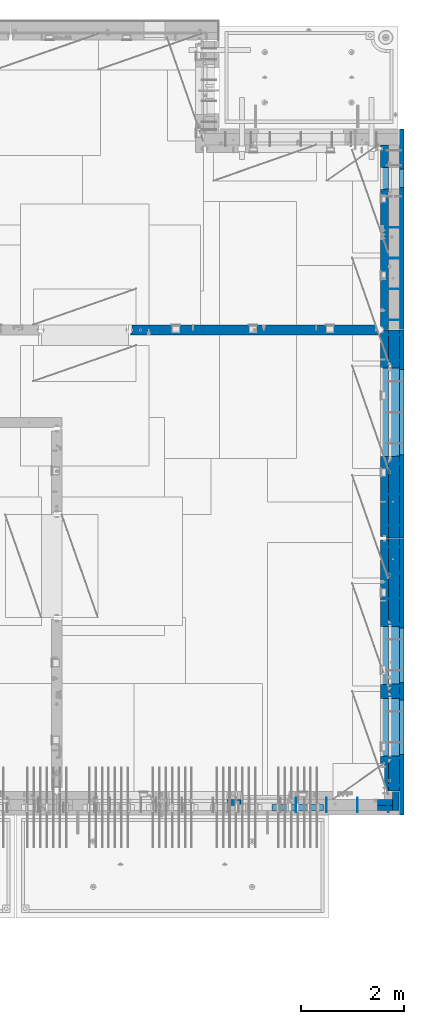
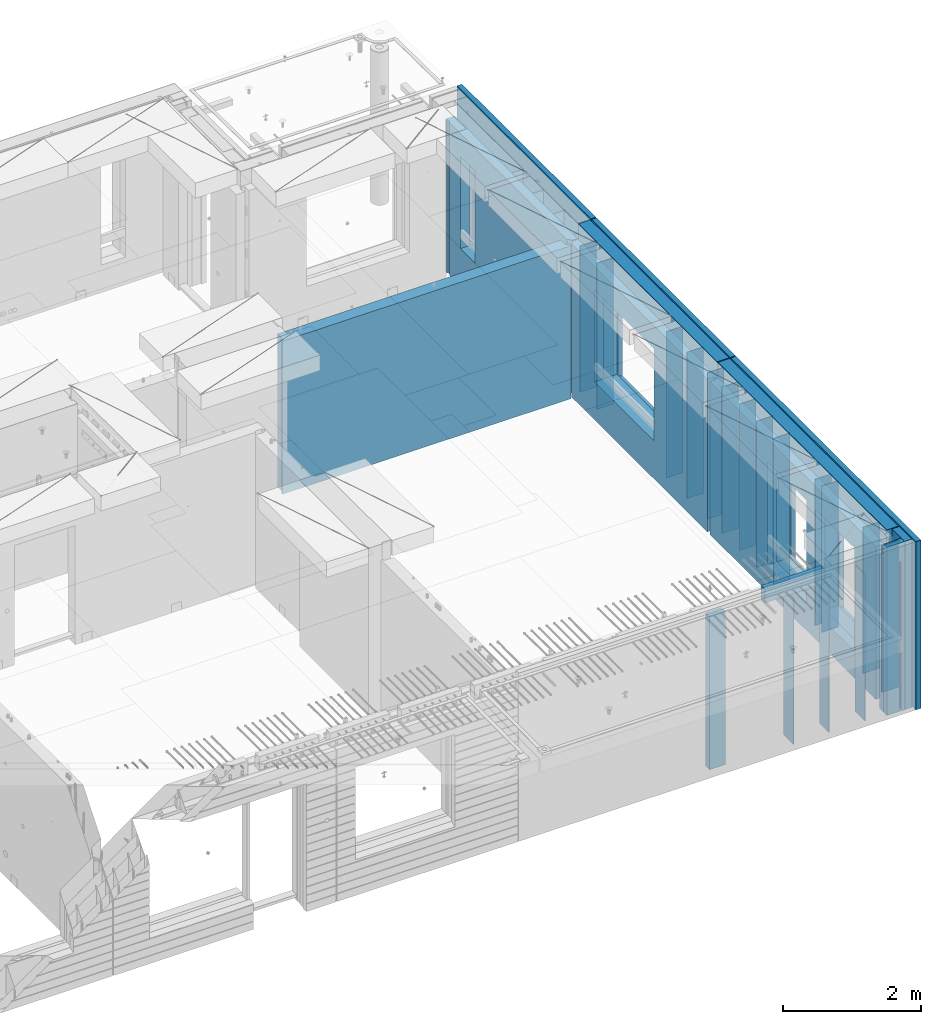
# One storey, part 242 of 350: 36 walls, 10 elements without a shape of their own.
"""IFC2X3 building model written with IfcOpenShell, lengths in millimetres."""

from ifc_helpers import new_model, si_unit, frame, origin_with_axes, place, context, subcontext, project, spatial, faceted_brep, material, type_object, element, aggregate, save


model = new_model("IFC2X3")

# Units and contexts
model_context = context("Model", 3, precision=1e-05, world=origin_with_axes())
body_context = subcontext(model_context, "Body", "Model", "MODEL_VIEW")
ifc_project = project(units=[si_unit("LENGTHUNIT", "METRE", prefix="MILLI"), si_unit("AREAUNIT", "SQUARE_METRE"), si_unit("VOLUMEUNIT", "CUBIC_METRE"), si_unit("MASSUNIT", "GRAM", prefix="KILO"), si_unit("TIMEUNIT", "SECOND"), si_unit("PLANEANGLEUNIT", "RADIAN"), si_unit("SOLIDANGLEUNIT", "STERADIAN"), si_unit("THERMODYNAMICTEMPERATUREUNIT", "DEGREE_CELSIUS"), si_unit("LUMINOUSINTENSITYUNIT", "LUMEN")], contexts=[model_context])

# Site, building, storey
site_placement = place(None, origin_with_axes())
site = spatial("IfcSite", under=ifc_project, at=site_placement, CompositionType="ELEMENT")
building_placement = place(site_placement, origin_with_axes())
building = spatial("IfcBuilding", under=site, at=building_placement, CompositionType="ELEMENT")
storey_placement = place(building_placement, origin_with_axes())
storey = spatial("IfcBuildingStorey", under=building, at=storey_placement, Name="2", CompositionType="ELEMENT", Elevation=0.0)

# Assembly, wall
assembly_1_placement = place(storey_placement, origin_with_axes())
assembly_1 = element("IfcElementAssembly", 1, at=assembly_1_placement, inside=storey, AssemblyPlace="NOTDEFINED", PredefinedType="REINFORCEMENT_UNIT")
ifc_material_1 = material(Name="Undefined")
wall_type_1 = type_object("IfcWallType", PredefinedType="NOTDEFINED")
wall_1_placement = place(assembly_1_placement, frame((35060.0, 7780.0, 86115.0), z_axis=(0.0, 0.0, 1.0), x_axis=(0.0, -1.0, 0.0)))
wall_1 = element("IfcWall", 2, at=wall_1_placement, type_object=wall_type_1, material=ifc_material_1, Name="(PD)", context=body_context, shape_type="Brep", body=[
    faceted_brep([(0.0, 5.0, -1300.0), (0.0, 5.0, 1300.0), (180.0, 5.0, 1300.0), (180.0, 5.0, -1300.0), (0.0, -5.0, 1300.0), (180.0, -5.0, 1300.0), (0.0, -5.0, -1300.0), (180.0, -5.0, -1300.0)], [[[0, 1, 2, 3]], [[1, 4, 5, 2]], [[4, 6, 7, 5]], [[6, 0, 3, 7]], [[5, 7, 3, 2]], [[6, 4, 1, 0]]]),
])

assembly_2_placement = place(storey_placement, origin_with_axes())
assembly_2 = element("IfcElementAssembly", 3, at=assembly_2_placement, inside=storey, Name="Steel Assembly", AssemblyPlace="NOTDEFINED", PredefinedType="NOTDEFINED")
wall_2_placement = place(assembly_2_placement, frame((34460.0, 7880.0, 86115.0), z_axis=(0.0, 0.0, 1.0), x_axis=(0.0, -1.0, 0.0)))
wall_2 = element("IfcWall", 4, at=wall_2_placement, type_object=wall_type_1, material=ifc_material_1, Name="(PD)", context=body_context, shape_type="Brep", body=[
    faceted_brep([(0.0, 5.0, -1300.0), (0.0, 5.0, 1300.0), (280.0, 5.0, 1300.0), (280.0, 5.0, -1300.0), (0.0, -5.0, 1300.0), (280.0, -5.0, 1300.0), (0.0, -5.0, -1300.0), (280.0, -5.0, -1300.0)], [[[0, 1, 2, 3]], [[1, 4, 5, 2]], [[4, 6, 7, 5]], [[6, 0, 3, 7]], [[5, 7, 3, 2]], [[6, 4, 1, 0]]]),
])
aggregate(assembly_2, [wall_2])

assembly_3_placement = place(storey_placement, origin_with_axes())
assembly_3 = element("IfcElementAssembly", 5, at=assembly_3_placement, inside=storey, Name="Steel Assembly", AssemblyPlace="NOTDEFINED", PredefinedType="NOTDEFINED")
wall_3_placement = place(assembly_3_placement, frame((33860.0, 7880.0, 86115.0), z_axis=(0.0, 0.0, 1.0), x_axis=(0.0, -1.0, 0.0)))
wall_3 = element("IfcWall", 6, at=wall_3_placement, type_object=wall_type_1, material=ifc_material_1, Name="(PD)", context=body_context, shape_type="Brep", body=[
    faceted_brep([(0.0, 5.0, -1300.0), (0.0, 5.0, 1300.0), (280.0, 5.0, 1300.0), (280.0, 5.0, -1300.0), (0.0, -5.0, 1300.0), (280.0, -5.0, 1300.0), (0.0, -5.0, -1300.0), (280.0, -5.0, -1300.0)], [[[0, 1, 2, 3]], [[1, 4, 5, 2]], [[4, 6, 7, 5]], [[6, 0, 3, 7]], [[5, 7, 3, 2]], [[6, 4, 1, 0]]]),
])
aggregate(assembly_3, [wall_3])

# Assembly, walls
assembly_4_placement = place(storey_placement, origin_with_axes())
assembly_4 = element("IfcElementAssembly", 7, at=assembly_4_placement, inside=storey, AssemblyPlace="NOTDEFINED", PredefinedType="REINFORCEMENT_UNIT")
wall_4_placement = place(assembly_4_placement, frame((35030.0, 12755.0002861023, 86115.0), z_axis=(0.0, 0.0, 1.0), x_axis=(1.0, 0.0, 0.0)))
wall_4 = element("IfcWall", 8, at=wall_4_placement, type_object=wall_type_1, material=ifc_material_1, Name="(PD)", context=body_context, shape_type="Brep", body=[
    faceted_brep([(0.0, 5.0, -1300.0), (0.0, 5.0, 1300.0), (280.0, 5.0, 1300.0), (280.0, 5.0, -1300.0), (0.0, -5.0, 1300.0), (280.0, -5.0, 1300.0), (0.0, -5.0, -1300.0), (280.0, -5.0, -1300.0)], [[[0, 1, 2, 3]], [[1, 4, 5, 2]], [[4, 6, 7, 5]], [[6, 0, 3, 7]], [[5, 7, 3, 2]], [[6, 4, 1, 0]]]),
])
wall_5_placement = place(assembly_4_placement, frame((35030.0, 12255.0002861023, 86115.0), z_axis=(0.0, 0.0, 1.0), x_axis=(1.0, 0.0, 0.0)))
wall_5 = element("IfcWall", 9, at=wall_5_placement, type_object=wall_type_1, material=ifc_material_1, Name="(PD)", context=body_context, shape_type="Brep", body=[
    faceted_brep([(0.0, 5.0, -1300.0), (0.0, 5.0, 1300.0), (280.0, 5.0, 1300.0), (280.0, 5.0, -1300.0), (0.0, -5.0, 1300.0), (280.0, -5.0, 1300.0), (0.0, -5.0, -1300.0), (280.0, -5.0, -1300.0)], [[[0, 1, 2, 3]], [[1, 4, 5, 2]], [[4, 6, 7, 5]], [[6, 0, 3, 7]], [[5, 7, 3, 2]], [[6, 4, 1, 0]]]),
])
wall_6_placement = place(assembly_4_placement, frame((35030.0, 11755.0002861023, 86115.0), z_axis=(0.0, 0.0, 1.0), x_axis=(1.0, 0.0, 0.0)))
wall_6 = element("IfcWall", 10, at=wall_6_placement, type_object=wall_type_1, material=ifc_material_1, Name="(PD)", context=body_context, shape_type="Brep", body=[
    faceted_brep([(0.0, 5.0, -1300.0), (0.0, 5.0, 1300.0), (280.0, 5.0, 1300.0), (280.0, 5.0, -1300.0), (0.0, -5.0, 1300.0), (280.0, -5.0, 1300.0), (0.0, -5.0, -1300.0), (280.0, -5.0, -1300.0)], [[[0, 1, 2, 3]], [[1, 4, 5, 2]], [[4, 6, 7, 5]], [[6, 0, 3, 7]], [[5, 7, 3, 2]], [[6, 4, 1, 0]]]),
])
wall_7_placement = place(assembly_4_placement, frame((35030.0, 11255.0002861023, 86115.0), z_axis=(0.0, 0.0, 1.0), x_axis=(1.0, 0.0, 0.0)))
wall_7 = element("IfcWall", 11, at=wall_7_placement, type_object=wall_type_1, material=ifc_material_1, Name="(PD)", context=body_context, shape_type="Brep", body=[
    faceted_brep([(0.0, 5.0, -1300.0), (0.0, 5.0, 1300.0), (280.0, 5.0, 1300.0), (280.0, 5.0, -1300.0), (0.0, -5.0, 1300.0), (280.0, -5.0, 1300.0), (0.0, -5.0, -1300.0), (280.0, -5.0, -1300.0)], [[[0, 1, 2, 3]], [[1, 4, 5, 2]], [[4, 6, 7, 5]], [[6, 0, 3, 7]], [[5, 7, 3, 2]], [[6, 4, 1, 0]]]),
])
wall_8_placement = place(assembly_4_placement, frame((35030.0, 8105.0, 86115.0), z_axis=(0.0, 0.0, 1.0), x_axis=(1.0, 0.0, 0.0)))
wall_8 = element("IfcWall", 12, at=wall_8_placement, type_object=wall_type_1, material=ifc_material_1, Name="(PD)", context=body_context, shape_type="Brep", body=[
    faceted_brep([(0.0, 5.0, -1300.0), (0.0, 5.0, 1300.0), (280.0, 5.0, 1300.0), (280.0, 5.0, -1300.0), (0.0, -5.0, 1300.0), (280.0, -5.0, 1300.0), (0.0, -5.0, -1300.0), (280.0, -5.0, -1300.0)], [[[0, 1, 2, 3]], [[1, 4, 5, 2]], [[4, 6, 7, 5]], [[6, 0, 3, 7]], [[5, 7, 3, 2]], [[6, 4, 1, 0]]]),
])
wall_9_placement = place(assembly_4_placement, frame((35030.0, 8115.0, 86115.0), z_axis=(0.0, 0.0, 1.0), x_axis=(1.0, 0.0, 0.0)))
wall_9 = element("IfcWall", 13, at=wall_9_placement, type_object=wall_type_1, material=ifc_material_1, Name="(PD)", context=body_context, shape_type="Brep", body=[
    faceted_brep([(0.0, 5.0, -1300.0), (0.0, 5.0, 1300.0), (280.0, 5.0, 1300.0), (280.0, 5.0, -1300.0), (0.0, -5.0, 1300.0), (280.0, -5.0, 1300.0), (0.0, -5.0, -1300.0), (280.0, -5.0, -1300.0)], [[[0, 1, 2, 3]], [[1, 4, 5, 2]], [[4, 6, 7, 5]], [[6, 0, 3, 7]], [[5, 7, 3, 2]], [[6, 4, 1, 0]]]),
])
wall_10_placement = place(assembly_4_placement, frame((35030.0, 9855.00028610229, 86115.0), z_axis=(0.0, 0.0, 1.0), x_axis=(1.0, 0.0, 0.0)))
wall_10 = element("IfcWall", 14, at=wall_10_placement, type_object=wall_type_1, material=ifc_material_1, Name="(PD)", context=body_context, shape_type="Brep", body=[
    faceted_brep([(0.0, 5.0, -1300.0), (0.0, 5.0, 1300.0), (280.0, 5.0, 1300.0), (280.0, 5.0, -1300.0), (0.0, -5.0, 1300.0), (280.0, -5.0, 1300.0), (0.0, -5.0, -1300.0), (280.0, -5.0, -1300.0)], [[[0, 1, 2, 3]], [[1, 4, 5, 2]], [[4, 6, 7, 5]], [[6, 0, 3, 7]], [[5, 7, 3, 2]], [[6, 4, 1, 0]]]),
])
wall_11_placement = place(assembly_4_placement, frame((35030.0, 10055.0002861023, 86115.0), z_axis=(0.0, 0.0, 1.0), x_axis=(1.0, 0.0, 0.0)))
wall_11 = element("IfcWall", 15, at=wall_11_placement, type_object=wall_type_1, material=ifc_material_1, Name="(PD)", context=body_context, shape_type="Brep", body=[
    faceted_brep([(0.0, 5.0, -1300.0), (0.0, 5.0, 1300.0), (280.0, 5.0, 1300.0), (280.0, 5.0, -1300.0), (0.0, -5.0, 1300.0), (280.0, -5.0, 1300.0), (0.0, -5.0, -1300.0), (280.0, -5.0, -1300.0)], [[[0, 1, 2, 3]], [[1, 4, 5, 2]], [[4, 6, 7, 5]], [[6, 0, 3, 7]], [[5, 7, 3, 2]], [[6, 4, 1, 0]]]),
])

assembly_5_placement = place(storey_placement, origin_with_axes())
assembly_5 = element("IfcElementAssembly", 16, at=assembly_5_placement, inside=storey, AssemblyPlace="NOTDEFINED", PredefinedType="REINFORCEMENT_UNIT")
wall_12_placement = place(assembly_5_placement, frame((35030.0, 13175.0002861023, 86115.0), z_axis=(0.0, 0.0, 1.0), x_axis=(1.0, 0.0, 0.0)))
wall_12 = element("IfcWall", 17, at=wall_12_placement, type_object=wall_type_1, material=ifc_material_1, Name="(PD)", context=body_context, shape_type="Brep", body=[
    faceted_brep([(0.0, 5.0, -1300.0), (0.0, 5.0, 1300.0), (280.0, 5.0, 1300.0), (280.0, 5.0, -1300.0), (0.0, -5.0, 1300.0), (280.0, -5.0, 1300.0), (0.0, -5.0, -1300.0), (280.0, -5.0, -1300.0)], [[[0, 1, 2, 3]], [[1, 4, 5, 2]], [[4, 6, 7, 5]], [[6, 0, 3, 7]], [[5, 7, 3, 2]], [[6, 4, 1, 0]]]),
])
wall_13_placement = place(assembly_5_placement, frame((35030.0, 13775.0002861023, 86115.0), z_axis=(0.0, 0.0, 1.0), x_axis=(1.0, 0.0, 0.0)))
wall_13 = element("IfcWall", 18, at=wall_13_placement, type_object=wall_type_1, material=ifc_material_1, Name="(PD)", context=body_context, shape_type="Brep", body=[
    faceted_brep([(0.0, 5.0, -1300.0), (0.0, 5.0, 1300.0), (280.0, 5.0, 1300.0), (280.0, 5.0, -1300.0), (0.0, -5.0, 1300.0), (280.0, -5.0, 1300.0), (0.0, -5.0, -1300.0), (280.0, -5.0, -1300.0)], [[[0, 1, 2, 3]], [[1, 4, 5, 2]], [[4, 6, 7, 5]], [[6, 0, 3, 7]], [[5, 7, 3, 2]], [[6, 4, 1, 0]]]),
])
wall_14_placement = place(assembly_5_placement, frame((35030.0, 16885.0002861023, 86115.0), z_axis=(0.0, 0.0, 1.0), x_axis=(1.0, 0.0, 0.0)))
wall_14 = element("IfcWall", 19, at=wall_14_placement, type_object=wall_type_1, material=ifc_material_1, Name="(PD)", context=body_context, shape_type="Brep", body=[
    faceted_brep([(0.0, 5.0, -1300.0), (0.0, 5.0, 1300.0), (280.0, 5.0, 1300.0), (280.0, 5.0, -1300.0), (0.0, -5.0, 1300.0), (280.0, -5.0, 1300.0), (0.0, -5.0, -1300.0), (280.0, -5.0, -1300.0)], [[[0, 1, 2, 3]], [[1, 4, 5, 2]], [[4, 6, 7, 5]], [[6, 0, 3, 7]], [[5, 7, 3, 2]], [[6, 4, 1, 0]]]),
])
wall_15_placement = place(assembly_5_placement, frame((35030.0, 16385.0002861023, 86115.0), z_axis=(0.0, 0.0, 1.0), x_axis=(1.0, 0.0, 0.0)))
wall_15 = element("IfcWall", 20, at=wall_15_placement, type_object=wall_type_1, material=ifc_material_1, Name="(PD)", context=body_context, shape_type="Brep", body=[
    faceted_brep([(0.0, 5.0, -1300.0), (0.0, 5.0, 1300.0), (280.0, 5.0, 1300.0), (280.0, 5.0, -1300.0), (0.0, -5.0, 1300.0), (280.0, -5.0, 1300.0), (0.0, -5.0, -1300.0), (280.0, -5.0, -1300.0)], [[[0, 1, 2, 3]], [[1, 4, 5, 2]], [[4, 6, 7, 5]], [[6, 0, 3, 7]], [[5, 7, 3, 2]], [[6, 4, 1, 0]]]),
])

assembly_6_placement = place(storey_placement, origin_with_axes())
assembly_6 = element("IfcElementAssembly", 21, at=assembly_6_placement, inside=storey, AssemblyPlace="NOTDEFINED", PredefinedType="REINFORCEMENT_UNIT")
wall_16_placement = place(assembly_6_placement, frame((35030.0, 17175.0002441406, 86115.0), z_axis=(0.0, 0.0, 1.0), x_axis=(1.0, 0.0, 0.0)))
wall_16 = element("IfcWall", 22, at=wall_16_placement, type_object=wall_type_1, material=ifc_material_1, Name="(PD)", context=body_context, shape_type="Brep", body=[
    faceted_brep([(0.0, 5.0, -1300.0), (0.0, 5.0, 1300.0), (280.0, 5.0, 1300.0), (280.0, 5.0, -1300.0), (0.0, -5.0, 1300.0), (280.0, -5.0, 1300.0), (0.0, -5.0, -1300.0), (280.0, -5.0, -1300.0)], [[[0, 1, 2, 3]], [[1, 4, 5, 2]], [[4, 6, 7, 5]], [[6, 0, 3, 7]], [[5, 7, 3, 2]], [[6, 4, 1, 0]]]),
])
wall_17_placement = place(assembly_6_placement, frame((35030.0, 17775.0002441406, 86115.0), z_axis=(0.0, 0.0, 1.0), x_axis=(1.0, 0.0, 0.0)))
wall_17 = element("IfcWall", 23, at=wall_17_placement, type_object=wall_type_1, material=ifc_material_1, Name="(PD)", context=body_context, shape_type="Brep", body=[
    faceted_brep([(0.0, 5.0, -1300.0), (0.0, 5.0, 1300.0), (280.0, 5.0, 1300.0), (280.0, 5.0, -1300.0), (0.0, -5.0, 1300.0), (280.0, -5.0, 1300.0), (0.0, -5.0, -1300.0), (280.0, -5.0, -1300.0)], [[[0, 1, 2, 3]], [[1, 4, 5, 2]], [[4, 6, 7, 5]], [[6, 0, 3, 7]], [[5, 7, 3, 2]], [[6, 4, 1, 0]]]),
])
wall_18_placement = place(assembly_6_placement, frame((35030.0, 18375.0002441406, 86115.0), z_axis=(0.0, 0.0, 1.0), x_axis=(1.0, 0.0, 0.0)))
wall_18 = element("IfcWall", 24, at=wall_18_placement, type_object=wall_type_1, material=ifc_material_1, Name="(PD)", context=body_context, shape_type="Brep", body=[
    faceted_brep([(0.0, 5.0, -1300.0), (0.0, 5.0, 1300.0), (280.0, 5.0, 1300.0), (280.0, 5.0, -1300.0), (0.0, -5.0, 1300.0), (280.0, -5.0, 1300.0), (0.0, -5.0, -1300.0), (280.0, -5.0, -1300.0)], [[[0, 1, 2, 3]], [[1, 4, 5, 2]], [[4, 6, 7, 5]], [[6, 0, 3, 7]], [[5, 7, 3, 2]], [[6, 4, 1, 0]]]),
])
wall_19_placement = place(assembly_6_placement, frame((35030.0, 18975.0002441406, 86115.0), z_axis=(0.0, 0.0, 1.0), x_axis=(1.0, 0.0, 0.0)))
wall_19 = element("IfcWall", 25, at=wall_19_placement, type_object=wall_type_1, material=ifc_material_1, Name="(PD)", context=body_context, shape_type="Brep", body=[
    faceted_brep([(0.0, 5.0, -1300.0), (0.0, 5.0, 1300.0), (280.0, 5.0, 1300.0), (280.0, 5.0, -1300.0), (0.0, -5.0, 1300.0), (280.0, -5.0, 1300.0), (0.0, -5.0, -1300.0), (280.0, -5.0, -1300.0)], [[[0, 1, 2, 3]], [[1, 4, 5, 2]], [[4, 6, 7, 5]], [[6, 0, 3, 7]], [[5, 7, 3, 2]], [[6, 4, 1, 0]]]),
])

# Assembly, wall
assembly_7_placement = place(storey_placement, origin_with_axes())
assembly_7 = element("IfcElementAssembly", 26, at=assembly_7_placement, inside=storey, Name="Steel Assembly", AssemblyPlace="NOTDEFINED", PredefinedType="NOTDEFINED")
wall_20_placement = place(assembly_7_placement, frame((33260.0, 7880.0, 86115.0), z_axis=(0.0, 0.0, 1.0), x_axis=(0.0, -1.0, 0.0)))
wall_20 = element("IfcWall", 27, at=wall_20_placement, type_object=wall_type_1, material=ifc_material_1, Name="(PD)", context=body_context, shape_type="Brep", body=[
    faceted_brep([(0.0, 5.0, -1300.0), (0.0, 5.0, 1300.0), (280.0, 5.0, 1300.0), (280.0, 5.0, -1300.0), (0.0, -5.0, 1300.0), (280.0, -5.0, 1300.0), (0.0, -5.0, -1300.0), (280.0, -5.0, -1300.0)], [[[0, 1, 2, 3]], [[1, 4, 5, 2]], [[4, 6, 7, 5]], [[6, 0, 3, 7]], [[5, 7, 3, 2]], [[6, 4, 1, 0]]]),
])
aggregate(assembly_7, [wall_20])

# Wall
wall_21_placement = place(assembly_4_placement, frame((35030.0, 8655.0, 86115.0), z_axis=(0.0, 0.0, 1.0), x_axis=(1.0, 0.0, 0.0)))
wall_21 = element("IfcWall", 28, at=wall_21_placement, type_object=wall_type_1, material=ifc_material_1, Name="(PD)", context=body_context, shape_type="Brep", body=[
    faceted_brep([(0.0, 5.0, -1300.0), (0.0, 5.0, 1300.0), (280.0, 5.0, 1300.0), (280.0, 5.0, -1300.0), (0.0, -5.0, 1300.0), (280.0, -5.0, 1300.0), (0.0, -5.0, -1300.0), (280.0, -5.0, -1300.0)], [[[0, 1, 2, 3]], [[1, 4, 5, 2]], [[4, 6, 7, 5]], [[6, 0, 3, 7]], [[5, 7, 3, 2]], [[6, 4, 1, 0]]]),
])

wall_22_placement = place(assembly_5_placement, frame((35030.0, 14375.0002861023, 86115.0), z_axis=(0.0, 0.0, 1.0), x_axis=(1.0, 0.0, 0.0)))
wall_22 = element("IfcWall", 29, at=wall_22_placement, type_object=wall_type_1, material=ifc_material_1, Name="(PD)", context=body_context, shape_type="Brep", body=[
    faceted_brep([(0.0, 5.0, -1300.0), (0.0, 5.0, 1300.0), (280.0, 5.0, 1300.0), (280.0, 5.0, -1300.0), (0.0, -5.0, 1300.0), (280.0, -5.0, 1300.0), (0.0, -5.0, -1300.0), (280.0, -5.0, -1300.0)], [[[0, 1, 2, 3]], [[1, 4, 5, 2]], [[4, 6, 7, 5]], [[6, 0, 3, 7]], [[5, 7, 3, 2]], [[6, 4, 1, 0]]]),
])

# Assembly, wall
assembly_8_placement = place(storey_placement, origin_with_axes())
assembly_8 = element("IfcElementAssembly", 30, at=assembly_8_placement, inside=storey, AssemblyPlace="NOTDEFINED", PredefinedType="REINFORCEMENT_UNIT")
ifc_material_2 = material(Name="CONCRETE/C25/30")
wall_type_2 = type_object("IfcWallType", PredefinedType="NOTDEFINED")
wall_23_placement = place(assembly_8_placement, frame((30040.0, 16980.0002441406, 86112.5), z_axis=(0.0, 0.0, 1.0), x_axis=(1.0, 0.0, 0.0)))
wall_23 = element("IfcWall", 31, at=wall_23_placement, type_object=wall_type_2, material=ifc_material_2, context=body_context, shape_type="Brep", body=[
    faceted_brep([(4785.0, 100.0, 1357.5), (4785.0, -30.0, 1357.5), (4785.0, -30.0, -1357.5), (4785.0, 100.0, -1357.5), (4840.0, -60.0, 1357.5), (4840.0, -60.0, -1357.5), (30.0003214753524, 100.0, 1357.5), (30.0003214753524, 100.0, -1357.5), (30.0003214753524, -57.0, -1357.5), (30.0003214753524, -57.0, 1357.5), (0.0, -70.0001393059865, -1357.5), (0.0, -70.0001393059865, 1357.5), (0.0, -100.0, -1357.5), (0.0, -100.0, 1357.5), (4840.0, -100.0, -1357.5), (4840.0, -100.0, 1357.5)], [[[0, 1, 2, 3]], [[4, 5, 2, 1]], [[6, 7, 8, 9]], [[9, 8, 10, 11]], [[12, 13, 11, 10]], [[13, 12, 14, 15]], [[0, 6, 9, 11, 13, 15, 4, 1]], [[7, 6, 0, 3]], [[14, 12, 10, 8, 7, 3, 2, 5]], [[15, 14, 5, 4]]]),
])
aggregate(assembly_8, [wall_23])

# Assemblies, wall
assembly_9_placement = place(storey_placement, origin_with_axes())
assembly_9 = element("IfcElementAssembly", 32, at=assembly_9_placement, inside=storey, AssemblyPlace="NOTDEFINED", PredefinedType="REINFORCEMENT_UNIT")
assembly_10_placement = place(assembly_9_placement, origin_with_axes())
assembly_10 = element("IfcElementAssembly", 33, at=assembly_10_placement, Name="Steel Assembly", AssemblyPlace="NOTDEFINED", PredefinedType="NOTDEFINED")
aggregate(assembly_9, [assembly_10])
ifc_material_3 = material()
wall_type_3 = type_object("IfcWallType", PredefinedType="NOTDEFINED")
wall_24_placement = place(assembly_10_placement, frame((32799.9998568133, 7690.00021946163, 87590.0), z_axis=(0.0, 0.0, 1.0), x_axis=(1.0, 0.0, 0.0)))
wall_24 = element("IfcWall", 34, at=wall_24_placement, type_object=wall_type_3, material=ifc_material_3, context=body_context, shape_type="Brep", body=[
    faceted_brep([(0.0, 60.0, -120.0), (0.0, 60.0, 120.0), (1000.0, 60.0, 120.0), (1000.0, 60.0, -120.0), (0.0, -60.0, 120.0), (1000.0, -60.0, 120.0), (0.0, -60.0, -120.0), (1000.0, -60.0, -120.0)], [[[0, 1, 2, 3]], [[1, 4, 5, 2]], [[4, 6, 7, 5]], [[6, 0, 3, 7]], [[5, 7, 3, 2]], [[6, 4, 1, 0]]]),
])
aggregate(assembly_10, [wall_24])

# Wall
ifc_material_4 = material(Name="COS5gt")
wall_type_4 = type_object("IfcWallType", PredefinedType="NOTDEFINED")
wall_25_placement = place(assembly_4_placement, frame((35170.0, 12920.0002861023, 86247.5), z_axis=(0.0, 0.0, 1.0), x_axis=(0.0, -1.0, 0.0)))
wall_25 = element("IfcWall", 35, at=wall_25_placement, type_object=wall_type_4, material=ifc_material_4, context=body_context, shape_type="Brep", body=[
    faceted_brep([(0.0, 90.0, 1492.5), (4905.00028610229, 90.0, 1492.5), (4905.00028610229, 90.0, 1442.5), (-0.25, 90.0, 1442.5), (0.0, -110.0, 1492.5), (4905.00028610229, -110.0, 1492.5), (4905.00028610229, 110.0, 1442.5), (4905.00028610229, -110.0, -1492.5), (4905.00028610229, 90.0, -1492.5), (4905.00028610229, 90.0, -1442.5), (4905.00028610229, 110.0, -1442.5), (-0.25, 110.0, 1442.5), (0.0, 90.0, -1492.5), (0.0, -110.0, -1492.5), (-0.25, 110.0, -1442.5), (-0.25, 90.0, -1442.5), (3115.00024333302, 110.0, -1007.5), (3145.00024333302, 110.0, -1007.5), (4195.00024333302, 110.0, -1007.5), (4225.00024333302, 110.0, -1007.5), (4225.00024333302, 110.0, -1002.5), (4225.00024333302, 110.0, 807.5), (3115.00024333302, 110.0, 807.5), (3115.00024333302, 110.0, -1002.5), (1715.00062480275, 110.0, -1007.5), (1745.00062480275, 110.0, -1007.5), (2795.00062480275, 110.0, -1007.5), (2825.00062480275, 110.0, -1007.5), (2825.00062480275, 110.0, -1002.5), (2825.00062480275, 110.0, 807.5), (1715.00062480275, 110.0, 807.5), (1715.00062480275, 110.0, -1002.5), (4230.94618927897, -110.0, -1013.44594594595), (4230.94618927897, -110.0, 813.445945945947), (3109.05429738708, -110.0, -1013.44594594595), (3109.05429738708, -110.0, 813.445945945947), (2830.9465707487, -110.0, -1013.44594594595), (1709.0546788568, -110.0, -1013.44594594595), (1709.0546788568, -110.0, 813.445945945947), (2830.9465707487, -110.0, 813.445945945947)], [[[0, 1, 2, 3]], [[4, 5, 1, 0]], [[6, 2, 1, 5, 7, 8, 9, 10]], [[11, 3, 2, 6]], [[12, 13, 4, 0, 3, 11, 14, 15]], [[7, 13, 12, 8]], [[15, 9, 8, 12]], [[14, 10, 9, 15]], [[11, 6, 10, 14], [16, 17, 18, 19, 20, 21, 22, 23], [24, 25, 26, 27, 28, 29, 30, 31]], [[20, 19, 32, 33, 21]], [[18, 17, 16, 34, 32, 19]], [[23, 22, 35, 34, 16]], [[21, 33, 35, 22]], [[4, 13, 7, 5], [32, 34, 35, 33], [36, 37, 38, 39]], [[26, 25, 24, 37, 36, 27]], [[31, 30, 38, 37, 24]], [[29, 39, 38, 30]], [[28, 27, 36, 39, 29]]]),
])

wall_26_placement = place(assembly_5_placement, frame((35170.0, 16980.0002861023, 86247.5), z_axis=(0.0, 0.0, 1.0), x_axis=(0.0, -1.0, 0.0)))
wall_26 = element("IfcWall", 36, at=wall_26_placement, type_object=wall_type_4, material=ifc_material_4, context=body_context, shape_type="Brep", body=[
    faceted_brep([(1409.0, 90.0, -1492.5), (1409.0, 90.0, -1442.5), (4045.0, 90.0, -1442.5), (4045.0, 90.0, -1492.5), (5.0, 110.0, -1492.5), (5.0, -110.0, -1492.5), (5.0, -110.0, 1492.5), (5.00004196166992, 90.0, 1492.5), (5.00004196166992, 90.0, 1442.5), (5.00004196166992, 110.0, 1442.5), (4045.0, -110.0, -1492.5), (4045.0, -110.0, 1492.5), (2460.94588410319, -110.0, -813.445945945947), (739.053992211293, -110.0, -813.445945945947), (739.053992211293, -110.0, 813.445945945947), (2460.94588410319, -110.0, 813.445945945947), (2454.99993815724, 110.0, 807.5), (744.99993815724, 110.0, 807.5), (2454.99993815724, 110.0, -802.5), (2454.99993815724, 110.0, -807.5), (2424.99993815724, 110.0, -807.5), (774.99993815724, 110.0, -807.5), (744.99993815724, 110.0, -807.5), (744.99993815724, 110.0, -802.5), (4045.0, 110.0, 1442.5), (4045.0, 110.0, -1442.5), (1409.0, 110.0, -1442.5), (1409.0, 110.0, -1492.5), (4045.0, 90.0, 1442.5), (4045.0, 90.0, 1492.5)], [[[0, 1, 2, 3]], [[4, 5, 6, 7, 8, 9]], [[6, 5, 10, 11], [12, 13, 14, 15]], [[16, 15, 14, 17]], [[18, 19, 12, 15, 16]], [[20, 21, 22, 13, 12, 19]], [[23, 17, 14, 13, 22]], [[4, 9, 24, 25, 26, 27], [22, 21, 20, 19, 18, 16, 17, 23]], [[3, 10, 5, 4, 27, 0]], [[26, 1, 0, 27]], [[25, 2, 1, 26]], [[24, 28, 29, 11, 10, 3, 2, 25]], [[9, 8, 28, 24]], [[7, 29, 28, 8]], [[6, 11, 29, 7]]]),
])

ifc_material_5 = material(Name="CONCRETE/C30/37")
wall_type_5 = type_object("IfcWallType", PredefinedType="NOTDEFINED")
wall_27_placement = place(assembly_4_placement, frame((35322.5, 12920.2502861023, 86247.5), z_axis=(0.0, 0.0, 1.0), x_axis=(0.0, -1.0, 0.0)))
wall_27 = element("IfcWall", 37, at=wall_27_placement, type_object=wall_type_5, material=ifc_material_5, context=body_context, shape_type="Brep", body=[
    faceted_brep([(0.0, 42.5, 1492.5), (0.0, -42.5, 1492.5), (5375.25028610229, -42.5, 1492.5), (5375.25028610229, 42.5, 1492.5), (0.0, -42.5, -1492.5), (0.0, 42.5, -1492.5), (5375.25028610229, 42.5, -1492.5), (5375.25028610229, -42.5, -1492.5), (4205.25024333302, 42.5, -1057.5), (4195.25024333302, -42.5, -1007.5), (4195.25024333302, -42.5, 782.5), (4195.25024333302, -42.5, 787.5), (4205.25024333302, 42.5, 782.5), (3135.25024333302, 42.5, -1057.5), (3145.25024333302, -42.5, -1007.5), (3135.25024333302, 42.5, 782.5), (3145.25024333302, -42.5, 787.5), (3145.25024333302, -42.5, 782.5), (3145.25024333302, 42.5, 782.5), (4195.25024333302, 42.5, 782.5), (2795.25062480275, -42.5, 782.5), (2795.25062480275, -42.5, -1007.5), (1745.25062480275, -42.5, -1007.5), (1745.25062480275, -42.5, 782.5), (1745.25062480275, -42.5, 787.5), (2795.25062480275, -42.5, 787.5), (1745.25062480275, 42.5, 782.5), (2795.25062480275, 42.5, 782.5), (2805.25062480275, 42.5, 782.5), (1735.25062480275, 42.5, 782.5), (2805.25062480275, 42.5, -1057.5), (1735.25062480275, 42.5, -1057.5)], [[[0, 1, 2, 3]], [[4, 5, 6, 7]], [[2, 7, 6, 3]], [[8, 9, 10, 11, 12]], [[13, 14, 9, 8]], [[15, 16, 17, 14, 13]], [[18, 19, 12, 11, 16, 15]], [[1, 4, 7, 2], [20, 21, 22, 23, 24, 25], [10, 9, 14, 17, 16, 11]], [[26, 27, 28, 25, 24, 29]], [[30, 21, 20, 25, 28]], [[31, 22, 21, 30]], [[29, 24, 23, 22, 31]], [[5, 0, 3, 6], [30, 28, 27, 26, 29, 31], [8, 12, 19, 18, 15, 13]], [[4, 1, 0, 5]]]),
])

wall_28_placement = place(assembly_5_placement, frame((35322.5, 16980.0002861023, 86247.5), z_axis=(0.0, 0.0, 1.0), x_axis=(0.0, -1.0, 0.0)))
wall_28 = element("IfcWall", 38, at=wall_28_placement, type_object=wall_type_5, material=ifc_material_5, context=body_context, shape_type="Brep", body=[
    faceted_brep([(5.00004196166992, 42.5, 1492.5), (5.00004196166992, -42.5, 1492.5), (4045.0, -42.5, 1492.5), (4045.0, 42.5, 1492.5), (5.00004196166992, -42.5, -1492.5), (5.00004196166992, 42.5, -1492.5), (4045.0, 42.5, -1492.5), (4045.0, -42.5, -1492.5), (2424.99993815724, -42.5, 782.5), (2424.99993815724, -42.5, 781.785034179688), (2424.99993815724, -42.5, -807.5), (774.99993815724, -42.5, -807.5), (774.99993815724, -42.5, 781.785034179688), (774.99993815724, -42.5, 782.5), (774.99993815724, -42.5, 787.5), (2424.99993815724, -42.5, 787.5), (774.99993815724, 42.5, 782.5), (2424.99993815724, 42.5, 782.5), (2434.99993815724, 42.5, 782.5), (764.99993815724, 42.5, 782.5), (2434.99993815724, 42.5, -857.5), (764.99993815724, 42.5, -857.5)], [[[0, 1, 2, 3]], [[4, 5, 6, 7]], [[2, 7, 6, 3]], [[1, 4, 7, 2], [8, 9, 10, 11, 12, 13, 14, 15]], [[16, 17, 18, 15, 14, 19]], [[20, 10, 9, 8, 15, 18]], [[21, 11, 10, 20]], [[19, 14, 13, 12, 11, 21]], [[5, 0, 3, 6], [20, 18, 17, 16, 19, 21]], [[4, 1, 0, 5]]]),
])

wall_29_placement = place(assembly_6_placement, frame((35322.5, 20432.0002441406, 86247.5), z_axis=(0.0, 0.0, 1.0), x_axis=(0.0, -1.0, 0.0)))
wall_29 = element("IfcWall", 39, at=wall_29_placement, type_object=wall_type_5, material=ifc_material_5, context=body_context, shape_type="Brep", body=[
    faceted_brep([(-453.0, -42.5, -1492.5), (-453.0, -42.5, 1492.5), (-453.0, 42.5, 1492.5), (-453.0, 42.5, -1492.5), (3442.0, 42.5, -1492.5), (3442.0, -42.5, -1492.5), (3442.0, -42.5, 1492.5), (677.000277665298, -42.5, 782.5), (677.000277665298, -42.5, -807.5), (327.000277665298, -42.5, -807.5), (327.000277665298, -42.5, 782.5), (327.000277665298, -42.5, 787.5), (677.000277665298, -42.5, 787.5), (327.000277665298, 42.5, 782.5), (677.000277665298, 42.5, 782.5), (687.000277665298, 42.5, 782.5), (317.000277665298, 42.5, 782.5), (687.000277665298, 42.5, -857.5), (317.000277665298, 42.5, -857.5), (3442.0, 42.5, 1492.5)], [[[0, 1, 2, 3]], [[0, 3, 4, 5]], [[1, 0, 5, 6], [7, 8, 9, 10, 11, 12]], [[13, 14, 15, 12, 11, 16]], [[17, 8, 7, 12, 15]], [[18, 9, 8, 17]], [[16, 11, 10, 9, 18]], [[3, 2, 19, 4], [17, 15, 14, 13, 16, 18]], [[6, 5, 4, 19]], [[2, 1, 6, 19]]]),
])

wall_type_6 = type_object("IfcWallType", PredefinedType="NOTDEFINED")
wall_30_placement = place(assembly_4_placement, frame((34985.0, 12920.0002861023, 86112.5), z_axis=(0.0, 0.0, 1.0), x_axis=(0.0, -1.0, 0.0)))
wall_30 = element("IfcWall", 40, at=wall_30_placement, type_object=wall_type_6, material=ifc_material_2, context=body_context, shape_type="Brep", body=[
    faceted_brep([(4855.00028610229, -75.0, 1357.5), (4855.00028610229, -75.0, -1357.5), (4855.00028610229, 32.0000069488524, -1357.5), (4855.00028610229, 32.0000069488524, 1357.5), (4905.00028610229, 45.0000069488524, 1357.5), (4905.00028610229, 45.0000069488524, -1357.5), (29.9999989126591, 32.0000004547946, 1357.5), (29.9999989126591, 32.0000004547946, -1357.5), (30.0000016637459, -75.0, -1357.5), (30.0000016637459, -75.0, 1357.5), (0.0, 45.0, 1357.5), (0.0, 45.0, -1357.5), (0.0, 75.0, 1357.5), (0.0, 75.0, -1357.5), (4905.00028610229, 75.0, -1357.5), (4905.00028610229, 75.0, 1357.5), (4230.94618927897, 75.0, 948.445945945947), (4235.00024333302, -75.0, 952.5), (3105.00024333302, -75.0, 952.5), (3109.05429738708, 75.0, 948.445945945947), (4230.94618927897, 75.0, -878.445945945947), (4235.00024333302, -75.0, -882.5), (3109.05429738708, 75.0, -878.445945945947), (3105.00024333302, -75.0, -882.5), (2830.9465707487, 75.0, -878.445945945947), (2830.9465707487, 75.0, 948.445945945947), (1709.0546788568, 75.0, 948.445945945947), (1709.0546788568, 75.0, -878.445945945947), (2835.00062480275, -75.0, -882.5), (2835.00062480275, -75.0, 952.5), (1705.00062480275, -75.0, -882.5), (1705.00062480275, -75.0, 952.5)], [[[0, 1, 2, 3]], [[4, 3, 2, 5]], [[6, 7, 8, 9]], [[10, 11, 7, 6]], [[12, 13, 11, 10]], [[1, 8, 7, 11, 13, 14, 5, 2]], [[14, 15, 4, 5]], [[16, 17, 18, 19]], [[20, 21, 17, 16]], [[22, 23, 21, 20]], [[19, 18, 23, 22]], [[13, 12, 15, 14], [20, 16, 19, 22], [24, 25, 26, 27]], [[24, 28, 29, 25]], [[27, 30, 28, 24]], [[26, 31, 30, 27]], [[25, 29, 31, 26]], [[9, 8, 1, 0], [28, 30, 31, 29], [21, 23, 18, 17]], [[15, 12, 10, 6, 9, 0, 3, 4]]]),
])

aggregate(assembly_4, [wall_4, wall_5, wall_6, wall_7, wall_8, wall_9, wall_10, wall_11, wall_21, wall_27, wall_25, wall_30])

wall_31_placement = place(assembly_5_placement, frame((34985.0, 16980.0002861023, 86112.5), z_axis=(0.0, 0.0, 1.0), x_axis=(0.0, -1.0, 0.0)))
wall_31 = element("IfcWall", 41, at=wall_31_placement, type_object=wall_type_6, material=ifc_material_2, context=body_context, shape_type="Brep", body=[
    faceted_brep([(5.0, 75.0, -1357.5), (5.0, 75.0, 1357.5), (4045.0, 75.0, 1357.5), (4045.0, 75.0, -1357.5), (2460.94588410319, 75.0, -678.445945945947), (2460.94588410319, 75.0, 948.445945945947), (739.053992211293, 75.0, 948.445945945947), (739.053992211293, 75.0, -678.445945945947), (5.0, -15.0000022791291, -1357.5), (5.0, -15.0000022791291, 1357.5), (65.0, -75.0, 1357.5), (65.0, -75.0, -1357.5), (4015.0, -75.0, 1357.5), (4015.0, 32.0, 1357.5), (4045.0, 45.0, 1357.5), (4045.0, 45.0, -1357.5), (4015.0, -75.0, -1357.5), (4015.0, 32.0, -1357.5), (2464.99993815724, -75.0, -682.5), (734.99993815724, -75.0, -682.5), (734.99993815724, -75.0, 952.5), (2464.99993815724, -75.0, 952.5)], [[[0, 1, 2, 3], [4, 5, 6, 7]], [[1, 0, 8, 9]], [[10, 9, 8, 11]], [[2, 1, 9, 10, 12, 13, 14]], [[3, 2, 14, 15]], [[16, 11, 8, 0, 3, 15, 17]], [[14, 13, 17, 15]], [[12, 16, 17, 13]], [[10, 11, 16, 12], [18, 19, 20, 21]], [[6, 20, 19, 7]], [[5, 21, 20, 6]], [[4, 18, 21, 5]], [[7, 19, 18, 4]]]),
])

aggregate(assembly_5, [wall_12, wall_13, wall_14, wall_15, wall_22, wall_26, wall_28, wall_31])

wall_32_placement = place(assembly_6_placement, frame((34985.0, 20575.0002441406, 86112.5), z_axis=(0.0, 0.0, 1.0), x_axis=(0.0, -1.0, 0.0)))
wall_32 = element("IfcWall", 42, at=wall_32_placement, type_object=wall_type_6, material=ifc_material_2, context=body_context, shape_type="Brep", body=[
    faceted_brep([(0.0, 75.0, -1357.5), (0.0, 75.0, 1357.5), (3585.0, 75.0, 1357.5), (3585.0, 75.0, -1357.5), (855.946223611245, 75.0, -678.445945945947), (855.946223611245, 75.0, 948.445945945947), (434.054331719351, 75.0, 948.445945945947), (434.054331719351, 75.0, -678.445945945947), (0.0, -75.0, -1357.5), (0.0, -75.0, 1357.5), (30.0050569130617, -75.0, -1357.5), (30.0050569130617, -75.0, 1357.5), (43.0050569130617, -55.0, -1357.5), (43.0050569130617, -55.0, 1357.5), (97.0050569130617, -55.0, -1357.5), (97.0050569130617, -55.0, 1357.5), (110.005056913062, -75.0, -1357.5), (110.005056913062, -75.0, 1357.5), (3525.0, -75.0, 1357.5), (3585.0, -15.0, 1357.5), (3585.0, -15.0, -1357.5), (3525.0, -75.0, -1357.5), (860.000277665298, -75.0, -682.5), (430.000277665298, -75.0, -682.5), (430.000277665298, -75.0, 952.5), (860.000277665298, -75.0, 952.5)], [[[0, 1, 2, 3], [4, 5, 6, 7]], [[8, 9, 1, 0]], [[9, 8, 10, 11]], [[11, 10, 12, 13]], [[13, 12, 14, 15]], [[15, 14, 16, 17]], [[2, 1, 9, 11, 13, 15, 17, 18, 19]], [[3, 2, 19, 20]], [[16, 14, 12, 10, 8, 0, 3, 20, 21]], [[19, 18, 21, 20]], [[17, 16, 21, 18], [22, 23, 24, 25]], [[6, 24, 23, 7]], [[5, 25, 24, 6]], [[4, 22, 25, 5]], [[7, 23, 22, 4]]]),
])

aggregate(assembly_6, [wall_16, wall_17, wall_18, wall_19, wall_29, wall_32])

ifc_material_6 = material(Name="SPU")
wall_type_7 = type_object("IfcWallType", PredefinedType="NOTDEFINED")
wall_33_placement = place(assembly_1_placement, frame((35205.0, 8000.0, 86247.5), z_axis=(0.0, 0.0, 1.0), x_axis=(0.0, -1.0, 0.0)))
wall_33 = element("IfcWall", 43, at=wall_33_placement, type_object=wall_type_7, material=ifc_material_6, context=body_context, shape_type="Brep", body=[
    faceted_brep([(0.0, 60.0, -1492.5), (0.0, 60.0, 1492.5), (370.0, 60.0, 1492.5), (370.0, 60.0, -1492.5), (0.0, -60.0, 1492.5), (370.0, -60.0, 1492.5), (0.0, -60.0, -1492.5), (370.0, -60.0, -1492.5)], [[[0, 1, 2, 3]], [[1, 4, 5, 2]], [[4, 6, 7, 5]], [[6, 0, 3, 7]], [[5, 7, 3, 2]], [[6, 4, 1, 0]]]),
])

ifc_material_7 = material(Name="CONCRETE/C35/45")
wall_type_8 = type_object("IfcWallType", PredefinedType="NOTDEFINED")
wall_34_placement = place(assembly_1_placement, frame((35145.0000381475, 7790.0, 86112.5), z_axis=(0.0, 0.0, 1.0), x_axis=(-1.0, 3.00000001838171e-08, 0.0)))
wall_34 = element("IfcWall", 44, at=wall_34_placement, type_object=wall_type_8, material=ifc_material_7, context=body_context, shape_type="Brep", body=[
    faceted_brep([(0.0, 60.0, -1357.5), (0.0, 60.0, 1357.5), (300.001908754726, 60.0, 1357.5), (300.001908754726, 60.0, -1357.5), (0.0, -60.0, 1357.5), (300.001908754726, -60.0, 1357.5), (0.0, -60.0, -1357.5), (300.001908754726, -60.0, -1357.5)], [[[0, 1, 2, 3]], [[1, 4, 5, 2]], [[4, 6, 7, 5]], [[6, 0, 3, 7]], [[5, 7, 3, 2]], [[6, 4, 1, 0]]]),
])

wall_35_placement = place(assembly_1_placement, frame((32195.0000381475, 7790.0, 86112.5), z_axis=(0.0, 0.0, 1.0), x_axis=(-1.0, 3.00000001838171e-08, 0.0)))
wall_35 = element("IfcWall", 45, at=wall_35_placement, type_object=wall_type_8, material=ifc_material_7, context=body_context, shape_type="Brep", body=[
    faceted_brep([(0.0, 60.0, -1357.5), (0.0, 60.0, 1357.5), (270.001908754726, 60.0, 1357.5), (270.001908754726, 60.0, -1357.5), (0.0, -60.0, 1357.5), (270.001908754726, -60.0, 1357.5), (0.0, -60.0, -1357.5), (270.001908754726, -60.0, -1357.5)], [[[0, 1, 2, 3]], [[1, 4, 5, 2]], [[4, 6, 7, 5]], [[6, 0, 3, 7]], [[5, 7, 3, 2]], [[6, 4, 1, 0]]]),
])

wall_type_9 = type_object("IfcWallType", PredefinedType="NOTDEFINED")
wall_36_placement = place(assembly_1_placement, frame((35145.0000381475, 7680.0, 86247.5), z_axis=(0.0, 0.0, 1.0), x_axis=(-1.0, 3.00000001838171e-08, 0.0)))
wall_36 = element("IfcWall", 46, at=wall_36_placement, type_object=wall_type_9, material=ifc_material_6, context=body_context, shape_type="Brep", body=[
    faceted_brep([(0.0, 50.0, -1492.5), (0.0, 50.0, 1492.5), (300.001908754726, 50.0, 1492.5), (300.001908754726, 50.0, -1492.5), (0.0, -50.0, 1492.5), (300.001908754726, -50.0, 1492.5), (0.0, -50.0, -1492.5), (300.001908754726, -50.0, -1492.5)], [[[0, 1, 2, 3]], [[1, 4, 5, 2]], [[4, 6, 7, 5]], [[6, 0, 3, 7]], [[5, 7, 3, 2]], [[6, 4, 1, 0]]]),
])

aggregate(assembly_1, [wall_36, wall_34, wall_1, wall_33, wall_35])

save(model, "model.ifc")
